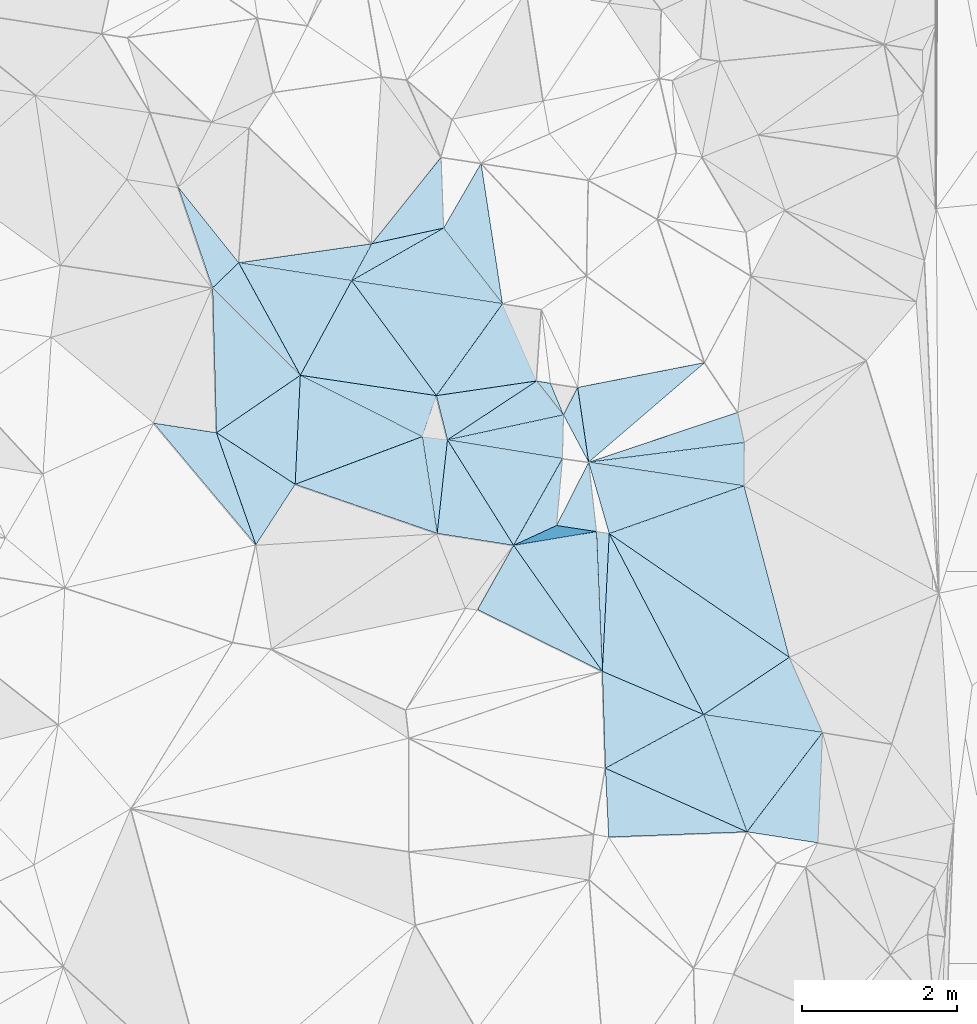
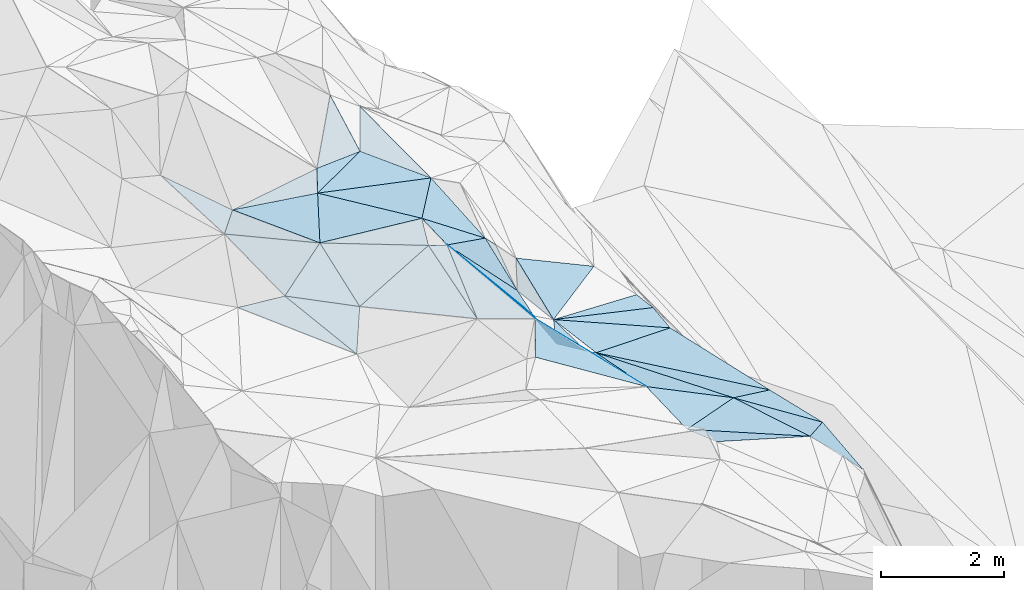
# One storey, part 136 of 275: 45 plates.
"""IFC2X3 building model written with IfcOpenShell, lengths in millimetres."""

from ifc_helpers import new_model, si_unit, frame, origin_with_axes, place, context, subcontext, project, spatial, polyline, outline, extrude, material, type_object, element, save


model = new_model("IFC2X3")

# Units and contexts
model_context = context("Model", 3, precision=1e-05, world=origin_with_axes())
body_context = subcontext(model_context, "Body", "Model", "MODEL_VIEW")
ifc_project = project(units=[si_unit("LENGTHUNIT", "METRE", prefix="MILLI"), si_unit("AREAUNIT", "SQUARE_METRE"), si_unit("VOLUMEUNIT", "CUBIC_METRE"), si_unit("MASSUNIT", "GRAM", prefix="KILO"), si_unit("TIMEUNIT", "SECOND"), si_unit("PLANEANGLEUNIT", "RADIAN"), si_unit("SOLIDANGLEUNIT", "STERADIAN"), si_unit("THERMODYNAMICTEMPERATUREUNIT", "DEGREE_CELSIUS"), si_unit("LUMINOUSINTENSITYUNIT", "LUMEN")], contexts=[model_context])

# Site, building, storey
site_placement = place(None, origin_with_axes())
site = spatial("IfcSite", under=ifc_project, at=site_placement, CompositionType="ELEMENT")
building_placement = place(site_placement, origin_with_axes())
building = spatial("IfcBuilding", under=site, at=building_placement, Name="Undefined", CompositionType="ELEMENT")
storey_placement = place(building_placement, origin_with_axes())
storey = spatial("IfcBuildingStorey", under=building, at=storey_placement, Name="Undefined", CompositionType="ELEMENT", Elevation=0.0)

# Plates
ifc_material = material()
plate_type_1 = type_object("IfcPlateType", PredefinedType="NOTDEFINED")
plate_1_placement = place(storey_placement, frame((-103066.712110477, 126934.664833472, 51469.7569913603), z_axis=(-0.382994864765174, -0.785585510736276, -0.485973598958555), x_axis=(0.529368234943565, 0.24448128612542, -0.812402715755675)))
element("IfcPlate", 1, at=plate_1_placement, inside=storey, type_object=plate_type_1, material=ifc_material, Name="00", context=body_context, shape_type="SweptSolid", body=[
    extrude(outline(polyline([(0.0, 0.0), (1046.27917480469, -4.88944351673126e-09), (1527.60388183594, 344.567138671875), (0.0, 0.0)])), frame((-8.85201319254618e-08, 2.18876761149539e-07, -0.5000001331573), z_axis=(0.0, 0.0, 1.0), x_axis=(1.0, 0.0, 0.0)), (0.0, 0.0, 1.0), 1.0),
])
plate_type_2 = type_object("IfcPlateType", PredefinedType="NOTDEFINED")
plate_2_placement = place(storey_placement, frame((-103066.905814277, 126935.033326246, 51469.6821244165), z_axis=(-0.770398967847582, -0.048593836914504, -0.63570753444749), x_axis=(-0.459656163311664, 0.733295490730213, 0.500992948856905)))
element("IfcPlate", 2, at=plate_2_placement, inside=storey, type_object=plate_type_2, material=ifc_material, Name="00", context=body_context, shape_type="SweptSolid", body=[
    extrude(outline(polyline([(0.0, 0.0), (1856.31359863281, -1.67819962371141e-08), (106.070442199707, 1537.87158203125), (0.0, 0.0)])), frame((-8.85201319254618e-08, 2.18876761149539e-07, -0.5000001331573), z_axis=(0.0, 0.0, 1.0), x_axis=(1.0, 0.0, 0.0)), (0.0, 0.0, 1.0), 1.0),
])
plate_type_3 = type_object("IfcPlateType", PredefinedType="NOTDEFINED")
plate_3_placement = place(storey_placement, frame((-101997.244580157, 127112.707123264, 50339.5594587975), z_axis=(-0.468511896336953, 0.0653125295690562, -0.881039656583087), x_axis=(-0.871098725838898, 0.132070881643551, 0.473016164696032)))
element("IfcPlate", 3, at=plate_3_placement, inside=storey, type_object=plate_type_3, material=ifc_material, Name="00", context=body_context, shape_type="SweptSolid", body=[
    extrude(outline(polyline([(0.0, 0.0), (591.945922851563, 2.6775524020195e-09), (262.861846923828, 870.519165039063), (0.0, 0.0)])), frame((-8.85201319254618e-08, 2.18876761149539e-07, -0.5000001331573), z_axis=(0.0, 0.0, 1.0), x_axis=(1.0, 0.0, 0.0)), (0.0, 0.0, 1.0), 1.0),
])
plate_type_4 = type_object("IfcPlateType", PredefinedType="NOTDEFINED")
plate_4_placement = place(storey_placement, frame((-100054.218506204, 123237.319774873, 50329.5073180374), z_axis=(-0.166949221869604, -0.0356923058343143, -0.985319246042298), x_axis=(-0.903457630635159, 0.405727496938867, 0.138381746899025)))
element("IfcPlate", 4, at=plate_4_placement, inside=storey, type_object=plate_type_4, material=ifc_material, Name="00", context=body_context, shape_type="SweptSolid", body=[
    extrude(outline(polyline([(0.0, 0.0), (2023.38830566406, -8.1636244431138e-09), (1124.89538574219, 1156.85375976563), (0.0, 0.0)])), frame((-8.85201319254618e-08, 2.18876761149539e-07, -0.5000001331573), z_axis=(0.0, 0.0, 1.0), x_axis=(1.0, 0.0, 0.0)), (0.0, 0.0, 1.0), 1.0),
])
plate_type_5 = type_object("IfcPlateType", PredefinedType="NOTDEFINED")
plate_5_placement = place(storey_placement, frame((-99138.9172299272, 123095.451423728, 49429.6417535888), z_axis=(-0.695161090337773, 0.0587561923549518, -0.7164487199656), x_axis=(-0.708825402116487, 0.109870213789418, 0.696774773823126)))
element("IfcPlate", 5, at=plate_5_placement, inside=storey, type_object=plate_type_5, material=ifc_material, Name="00", context=body_context, shape_type="SweptSolid", body=[
    extrude(outline(polyline([(0.0, 0.0), (1291.66564941406, 3.20142135024071e-09), (156.851745605469, 1419.25952148438), (0.0, 0.0)])), frame((-8.85201319254618e-08, 2.18876761149539e-07, -0.5000001331573), z_axis=(0.0, 0.0, 1.0), x_axis=(1.0, 0.0, 0.0)), (0.0, 0.0, 1.0), 1.0),
])
plate_type_6 = type_object("IfcPlateType", PredefinedType="NOTDEFINED")
plate_6_placement = place(storey_placement, frame((-105156.498019065, 130351.74544064, 52609.5000495979), z_axis=(0.0169326651673367, -0.000995935769564244, -0.999856136132731), x_axis=(0.593086249346957, -0.80506587780859, 0.0108458851110849)))
element("IfcPlate", 6, at=plate_6_placement, inside=storey, type_object=plate_type_6, material=ifc_material, Name="00", context=body_context, shape_type="SweptSolid", body=[
    extrude(outline(polyline([(0.0, 0.0), (1844.01733398438, 8.07540345704183e-09), (590.992248535156, 1258.3037109375), (0.0, 0.0)])), frame((-8.85201319254618e-08, 2.18876761149539e-07, -0.5000001331573), z_axis=(0.0, 0.0, 1.0), x_axis=(1.0, 0.0, 0.0)), (0.0, 0.0, 1.0), 1.0),
])
plate_type_7 = type_object("IfcPlateType", PredefinedType="NOTDEFINED")
plate_7_placement = place(storey_placement, frame((-105885.6027306, 127722.540343427, 52219.517241614), z_axis=(0.0183046440827062, 0.2598589496467, -0.965473079010243), x_axis=(-0.829176545301088, 0.543523481743129, 0.130569833868237)))
element("IfcPlate", 7, at=plate_7_placement, inside=storey, type_object=plate_type_7, material=ifc_material, Name="00", context=body_context, shape_type="SweptSolid", body=[
    extrude(outline(polyline([(0.0, 0.0), (1225.39794921875, 4.59112925454974e-09), (759.100402832031, 1246.06042480469), (0.0, 0.0)])), frame((-8.85201319254618e-08, 2.18876761149539e-07, -0.5000001331573), z_axis=(0.0, 0.0, 1.0), x_axis=(1.0, 0.0, 0.0)), (0.0, 0.0, 1.0), 1.0),
])
plate_type_8 = type_object("IfcPlateType", PredefinedType="NOTDEFINED")
plate_8_placement = place(storey_placement, frame((-103209.69435404, 130053.542712366, 52409.5065180733), z_axis=(-0.0799384784793379, 0.139991515799909, -0.986920571861005), x_axis=(-0.983409152696875, 0.150666100545945, 0.101025563786073)))
element("IfcPlate", 8, at=plate_8_placement, inside=storey, type_object=plate_type_8, material=ifc_material, Name="00", context=body_context, shape_type="SweptSolid", body=[
    extrude(outline(polyline([(0.0, 0.0), (1979.69689941406, 5.2241375669837e-09), (914.281372070313, 856.790283203125), (0.0, 0.0)])), frame((-8.85201319254618e-08, 2.18876761149539e-07, -0.5000001331573), z_axis=(0.0, 0.0, 1.0), x_axis=(1.0, 0.0, 0.0)), (0.0, 0.0, 1.0), 1.0),
])
plate_type_9 = type_object("IfcPlateType", PredefinedType="NOTDEFINED")
plate_9_placement = place(storey_placement, frame((-104002.079675067, 131944.846912686, 53179.5834194462), z_axis=(-0.210377469190595, 0.511525957004298, -0.833116147825618), x_axis=(0.030345762468046, -0.848360430690133, -0.528548686820321)))
element("IfcPlate", 9, at=plate_9_placement, inside=storey, type_object=plate_type_9, material=ifc_material, Name="00", context=body_context, shape_type="SweptSolid", body=[
    extrude(outline(polyline([(0.0, 0.0), (1078.4248046875, -5.28234522789717e-09), (1163.734375, 951.746948242188), (0.0, 0.0)])), frame((-8.85201319254618e-08, 2.18876761149539e-07, -0.5000001331573), z_axis=(0.0, 0.0, 1.0), x_axis=(1.0, 0.0, 0.0)), (0.0, 0.0, 1.0), 1.0),
])
plate_type_10 = type_object("IfcPlateType", PredefinedType="NOTDEFINED")
plate_10_placement = place(storey_placement, frame((-105156.595969258, 130351.902646769, 52609.5336799128), z_axis=(-0.178971071812995, 0.31342142105299, -0.93259657316507), x_axis=(0.469817430518854, 0.860067539019445, 0.198885420043041)))
element("IfcPlate", 10, at=plate_10_placement, inside=storey, type_object=plate_type_10, material=ifc_material, Name="00", context=body_context, shape_type="SweptSolid", body=[
    extrude(outline(polyline([(0.0, 0.0), (553.082275390625, 2.06637196242809e-09), (1140.87915039063, 753.388916015625), (0.0, 0.0)])), frame((-8.85201319254618e-08, 2.18876761149539e-07, -0.5000001331573), z_axis=(0.0, 0.0, 1.0), x_axis=(1.0, 0.0, 0.0)), (0.0, 0.0, 1.0), 1.0),
])
plate_type_11 = type_object("IfcPlateType", PredefinedType="NOTDEFINED")
plate_11_placement = place(storey_placement, frame((-104053.209064969, 127089.545762139, 51719.5724973247), z_axis=(-0.145791464487373, 0.497780816117161, -0.854961465791506), x_axis=(-0.129837787394665, 0.847093099972046, 0.515340109970306)))
element("IfcPlate", 11, at=plate_11_placement, inside=storey, type_object=plate_type_11, material=ifc_material, Name="00", context=body_context, shape_type="SweptSolid", body=[
    extrude(outline(polyline([(0.0, 0.0), (1474.75427246094, -9.41508915275335e-09), (1355.5478515625, 315.420135498047), (0.0, 0.0)])), frame((-8.85201319254618e-08, 2.18876761149539e-07, -0.5000001331573), z_axis=(0.0, 0.0, 1.0), x_axis=(1.0, 0.0, 0.0)), (0.0, 0.0, 1.0), 1.0),
])
plate_type_12 = type_object("IfcPlateType", PredefinedType="NOTDEFINED")
plate_12_placement = place(storey_placement, frame((-100173.620638357, 128651.436566187, 49889.5240167244), z_axis=(-0.300994349342359, 0.0569460371075263, -0.951924130654181), x_axis=(0.2106562983872, -0.96958546479659, -0.124611196948681)))
element("IfcPlate", 12, at=plate_12_placement, inside=storey, type_object=plate_type_12, material=ifc_material, Name="00", context=body_context, shape_type="SweptSolid", body=[
    extrude(outline(polyline([(0.0, 0.0), (401.248046875, -9.53150447458029e-10), (147.041213989258, 2102.32690429688), (0.0, 0.0)])), frame((-8.85201319254618e-08, 2.18876761149539e-07, -0.5000001331573), z_axis=(0.0, 0.0, 1.0), x_axis=(1.0, 0.0, 0.0)), (0.0, 0.0, 1.0), 1.0),
])
plate_type_13 = type_object("IfcPlateType", PredefinedType="NOTDEFINED")
plate_13_placement = place(storey_placement, frame((-99508.7822092477, 125490.317361758, 49689.5681303042), z_axis=(-0.502106992912468, -0.0438027793652822, -0.863695481166988), x_axis=(0.397332946452071, -0.898749384145857, -0.185407858951985)))
element("IfcPlate", 13, at=plate_13_placement, inside=storey, type_object=plate_type_13, material=ifc_material, Name="00", context=body_context, shape_type="SweptSolid", body=[
    extrude(outline(polyline([(0.0, 0.0), (1078.70288085938, -5.49334799870849e-09), (99.9348373413086, 1490.44055175781), (0.0, 0.0)])), frame((-8.85201319254618e-08, 2.18876761149539e-07, -0.5000001331573), z_axis=(0.0, 0.0, 1.0), x_axis=(1.0, 0.0, 0.0)), (0.0, 0.0, 1.0), 1.0),
])
plate_type_14 = type_object("IfcPlateType", PredefinedType="NOTDEFINED")
plate_14_placement = place(storey_placement, frame((-102422.71177586, 128619.656924779, 50779.7394256454), z_axis=(-0.364909545924037, 0.771550032679536, -0.521106102790708), x_axis=(-0.329776131223322, 0.416305903744311, 0.847311688685463)))
element("IfcPlate", 14, at=plate_14_placement, inside=storey, type_object=plate_type_14, material=ifc_material, Name="00", context=body_context, shape_type="SweptSolid", body=[
    extrude(outline(polyline([(0.0, 0.0), (1050.380859375, 2.39379005506635e-09), (834.935241699219, 122.405754089355), (0.0, 0.0)])), frame((-8.85201319254618e-08, 2.18876761149539e-07, -0.5000001331573), z_axis=(0.0, 0.0, 1.0), x_axis=(1.0, 0.0, 0.0)), (0.0, 0.0, 1.0), 1.0),
])
plate_type_15 = type_object("IfcPlateType", PredefinedType="NOTDEFINED")
plate_15_placement = place(storey_placement, frame((-105818.854998425, 129129.679469331, 52599.5172975869), z_axis=(0.0546115083904308, 0.255140506767915, -0.965360505178005), x_axis=(0.988881310890819, -0.147744193600586, 0.0168939701718752)))
element("IfcPlate", 15, at=plate_15_placement, inside=storey, type_object=plate_type_15, material=ifc_material, Name="00", context=body_context, shape_type="SweptSolid", body=[
    extrude(outline(polyline([(0.0, 0.0), (1775.78149414063, -5.47152012586594e-09), (1671.60205078125, 569.338745117188), (0.0, 0.0)])), frame((-8.85201319254618e-08, 2.18876761149539e-07, -0.5000001331573), z_axis=(0.0, 0.0, 1.0), x_axis=(1.0, 0.0, 0.0)), (0.0, 0.0, 1.0), 1.0),
])
plate_type_16 = type_object("IfcPlateType", PredefinedType="NOTDEFINED")
plate_16_placement = place(storey_placement, frame((-101839.387213726, 123169.617460363, 50889.543433549), z_axis=(-0.275045769895262, -0.301033493713015, -0.913087432903147), x_axis=(-0.0460346862578489, 0.952751163976744, -0.300243280028215)))
element("IfcPlate", 16, at=plate_16_placement, inside=storey, type_object=plate_type_16, material=ifc_material, Name="00", context=body_context, shape_type="SweptSolid", body=[
    extrude(outline(polyline([(0.0, 0.0), (932.577087402344, -4.13274392485619e-09), (150.33610534668, 1866.06518554688), (0.0, 0.0)])), frame((-8.85201319254618e-08, 2.18876761149539e-07, -0.5000001331573), z_axis=(0.0, 0.0, 1.0), x_axis=(1.0, 0.0, 0.0)), (0.0, 0.0, 1.0), 1.0),
])
plate_type_17 = type_object("IfcPlateType", PredefinedType="NOTDEFINED")
plate_17_placement = place(storey_placement, frame((-106614.10627522, 130582.056217532, 52649.5002354911), z_axis=(-0.0240748526667977, 0.0212253111247424, -0.999484811108568), x_axis=(0.98738418304366, -0.15600724560056, -0.0270963908174355)))
element("IfcPlate", 17, at=plate_17_placement, inside=storey, type_object=plate_type_17, material=ifc_material, Name="00", context=body_context, shape_type="SweptSolid", body=[
    extrude(outline(polyline([(0.0, 0.0), (1476.21142578125, -2.3283064365387e-10), (1013.13403320313, 1310.78576660156), (0.0, 0.0)])), frame((-8.85201319254618e-08, 2.18876761149539e-07, -0.5000001331573), z_axis=(0.0, 0.0, 1.0), x_axis=(1.0, 0.0, 0.0)), (0.0, 0.0, 1.0), 1.0),
])
plate_type_18 = type_object("IfcPlateType", PredefinedType="NOTDEFINED")
plate_18_placement = place(storey_placement, frame((-105818.854296588, 129129.680809976, 52599.5176946139), z_axis=(0.0560211159721772, 0.257825415463016, -0.964566062904224), x_axis=(0.891481974421891, -0.447930950772442, -0.0679540478628291)))
element("IfcPlate", 18, at=plate_18_placement, inside=storey, type_object=plate_type_18, material=ifc_material, Name="00", context=body_context, shape_type="SweptSolid", body=[
    extrude(outline(polyline([(0.0, 0.0), (1765.89916992188, -2.35741026699543e-09), (596.636535644531, 1331.51220703125), (0.0, 0.0)])), frame((-8.85201319254618e-08, 2.18876761149539e-07, -0.5000001331573), z_axis=(0.0, 0.0, 1.0), x_axis=(1.0, 0.0, 0.0)), (0.0, 0.0, 1.0), 1.0),
])
plate_type_19 = type_object("IfcPlateType", PredefinedType="NOTDEFINED")
plate_19_placement = place(storey_placement, frame((-102098.054796665, 128008.632321215, 50459.630739177), z_axis=(-0.505823591700289, 0.445861525208466, -0.738478161097672), x_axis=(-0.119673009436762, 0.811523430091826, 0.571933644074508)))
element("IfcPlate", 19, at=plate_19_placement, inside=storey, type_object=plate_type_19, material=ifc_material, Name="00", context=body_context, shape_type="SweptSolid", body=[
    extrude(outline(polyline([(0.0, 0.0), (1188.94909667969, 7.11588654667139e-09), (720.972839355469, 1854.64233398438), (0.0, 0.0)])), frame((-8.85201319254618e-08, 2.18876761149539e-07, -0.5000001331573), z_axis=(0.0, 0.0, 1.0), x_axis=(1.0, 0.0, 0.0)), (0.0, 0.0, 1.0), 1.0),
])
plate_type_20 = type_object("IfcPlateType", PredefinedType="NOTDEFINED")
plate_20_placement = place(storey_placement, frame((-106614.09015682, 130582.156129076, 52649.5123642163), z_axis=(0.00816414637942778, 0.221055638284513, -0.975227025618405), x_axis=(0.989141382463957, 0.141329248330167, 0.0403158661536777)))
element("IfcPlate", 20, at=plate_20_placement, inside=storey, type_object=plate_type_20, material=ifc_material, Name="00", context=body_context, shape_type="SweptSolid", body=[
    extrude(outline(polyline([(0.0, 0.0), (1736.28918457031, 1.80443748831749e-09), (1407.599609375, 444.818176269531), (0.0, 0.0)])), frame((-8.85201319254618e-08, 2.18876761149539e-07, -0.5000001331573), z_axis=(0.0, 0.0, 1.0), x_axis=(1.0, 0.0, 0.0)), (0.0, 0.0, 1.0), 1.0),
])
plate_type_21 = type_object("IfcPlateType", PredefinedType="NOTDEFINED")
plate_21_placement = place(storey_placement, frame((-102769.257546251, 129056.812479674, 51669.7400439502), z_axis=(-0.675333978190998, 0.523126903156167, -0.519867541874812), x_axis=(0.329776131234809, -0.416305903726012, -0.847311688689983)))
element("IfcPlate", 21, at=plate_21_placement, inside=storey, type_object=plate_type_21, material=ifc_material, Name="00", context=body_context, shape_type="SweptSolid", body=[
    extrude(outline(polyline([(0.0, 0.0), (1050.380859375, 2.39379005506635e-09), (-681.562316894531, 1403.87780761719), (0.0, 0.0)])), frame((-8.85201319254618e-08, 2.18876761149539e-07, -0.5000001331573), z_axis=(0.0, 0.0, 1.0), x_axis=(1.0, 0.0, 0.0)), (0.0, 0.0, 1.0), 1.0),
])
plate_type_22 = type_object("IfcPlateType", PredefinedType="NOTDEFINED")
plate_22_placement = place(storey_placement, frame((-102422.354827003, 128619.557998692, 50779.6294801499), z_axis=(0.348997443232228, 0.573694274328088, -0.740996399600252), x_axis=(0.339843211480445, 0.659407972874778, 0.67058759078873)))
element("IfcPlate", 22, at=plate_22_placement, inside=storey, type_object=plate_type_22, material=ifc_material, Name="00", context=body_context, shape_type="SweptSolid", body=[
    extrude(outline(polyline([(0.0, 0.0), (536.842651367188, 2.73576006293297e-09), (-507.038726806641, 569.132446289063), (0.0, 0.0)])), frame((-8.85201319254618e-08, 2.18876761149539e-07, -0.5000001331573), z_axis=(0.0, 0.0, 1.0), x_axis=(1.0, 0.0, 0.0)), (0.0, 0.0, 1.0), 1.0),
])
plate_type_23 = type_object("IfcPlateType", PredefinedType="NOTDEFINED")
plate_23_placement = place(storey_placement, frame((-102097.954518476, 128008.461281645, 50459.5266815143), z_axis=(-0.305270069071518, 0.103782140430351, -0.94659360459321), x_axis=(0.948630073739691, 0.119923310330751, -0.292778726747594)))
element("IfcPlate", 23, at=plate_23_placement, inside=storey, type_object=plate_type_23, material=ifc_material, Name="00", context=body_context, shape_type="SweptSolid", body=[
    extrude(outline(polyline([(0.0, 0.0), (2117.64013671875, -9.74978320300579e-09), (2064.1845703125, 560.127197265625), (0.0, 0.0)])), frame((-8.85201319254618e-08, 2.18876761149539e-07, -0.5000001331573), z_axis=(0.0, 0.0, 1.0), x_axis=(1.0, 0.0, 0.0)), (0.0, 0.0, 1.0), 1.0),
])
plate_type_24 = type_object("IfcPlateType", PredefinedType="NOTDEFINED")
plate_24_placement = place(storey_placement, frame((-107395.99566594, 131559.526923699, 53019.5411455461), z_axis=(0.0572261287580706, 0.393214546177214, -0.917664149273585), x_axis=(0.59911415129813, -0.748794737727581, -0.283493693873082)))
element("IfcPlate", 24, at=plate_24_placement, inside=storey, type_object=plate_type_24, material=ifc_material, Name="00", context=body_context, shape_type="SweptSolid", body=[
    extrude(outline(polyline([(0.0, 0.0), (1305.14367675781, -6.87577994540334e-09), (1390.9580078125, 487.273956298828), (0.0, 0.0)])), frame((-8.85201319254618e-08, 2.18876761149539e-07, -0.5000001331573), z_axis=(0.0, 0.0, 1.0), x_axis=(1.0, 0.0, 0.0)), (0.0, 0.0, 1.0), 1.0),
])
plate_type_25 = type_object("IfcPlateType", PredefinedType="NOTDEFINED")
plate_25_placement = place(storey_placement, frame((-104063.146722964, 128867.27218365, 52629.6096196503), z_axis=(-0.60314689515624, 0.16338829004905, -0.780716395074572), x_axis=(0.797610766574611, 0.116726921239208, -0.591770133499721)))
element("IfcPlate", 25, at=plate_25_placement, inside=storey, type_object=plate_type_25, material=ifc_material, Name="00", context=body_context, shape_type="SweptSolid", body=[
    extrude(outline(polyline([(0.0, 0.0), (1622.25146484375, 9.37143340706825e-09), (183.572021484375, 604.649719238281), (0.0, 0.0)])), frame((-8.85201319254618e-08, 2.18876761149539e-07, -0.5000001331573), z_axis=(0.0, 0.0, 1.0), x_axis=(1.0, 0.0, 0.0)), (0.0, 0.0, 1.0), 1.0),
])
plate_26_placement = place(storey_placement, frame((-103209.637819242, 130053.585348105, 52409.5131117536), z_axis=(0.0331302819806398, 0.225267890240316, -0.973733414258009), x_axis=(-0.606222378485492, 0.779112777976185, 0.15961737692878)))
element("IfcPlate", 26, at=plate_26_placement, inside=storey, type_object=plate_type_25, material=ifc_material, Name="00", context=body_context, shape_type="SweptSolid", body=[
    extrude(outline(polyline([(0.0, 0.0), (1252.99645996094, 1.09139364212751e-08), (1645.65515136719, 907.314208984375), (0.0, 0.0)])), frame((-8.85201319254618e-08, 2.18876761149539e-07, -0.5000001331573), z_axis=(0.0, 0.0, 1.0), x_axis=(1.0, 0.0, 0.0)), (0.0, 0.0, 1.0), 1.0),
])
plate_type_26 = type_object("IfcPlateType", PredefinedType="NOTDEFINED")
plate_27_placement = place(storey_placement, frame((-102436.242633563, 128055.816597882, 50619.7357655988), z_axis=(-0.845649645593804, 0.0751215211701313, -0.528425428952997), x_axis=(-0.0884844706384615, -0.996077556446199, -1.45631143495468e-11)))
element("IfcPlate", 27, at=plate_27_placement, inside=storey, type_object=plate_type_26, material=ifc_material, Name="00", context=body_context, shape_type="SweptSolid", body=[
    extrude(outline(polyline([(0.0, 0.0), (868.331726074219, -3.91446519643068e-09), (1172.13269042969, 1001.20178222656), (0.0, 0.0)])), frame((-8.85201319254618e-08, 2.18876761149539e-07, -0.5000001331573), z_axis=(0.0, 0.0, 1.0), x_axis=(1.0, 0.0, 0.0)), (0.0, 0.0, 1.0), 1.0),
])
plate_type_27 = type_object("IfcPlateType", PredefinedType="NOTDEFINED")
plate_28_placement = place(storey_placement, frame((-101921.481577274, 125309.395571691, 50709.5338117634), z_axis=(-0.255568071387647, 0.255816673667284, -0.932331909976809), x_axis=(-0.841164731122259, 0.416541404691041, 0.344869762800441)))
element("IfcPlate", 28, at=plate_28_placement, inside=storey, type_object=plate_type_27, material=ifc_material, Name="00", context=body_context, shape_type="SweptSolid", body=[
    extrude(outline(polyline([(0.0, 0.0), (1913.76586914063, 1.4202669262886e-08), (1902.58374023438, 955.183227539063), (0.0, 0.0)])), frame((-8.85201319254618e-08, 2.18876761149539e-07, -0.5000001331573), z_axis=(0.0, 0.0, 1.0), x_axis=(1.0, 0.0, 0.0)), (0.0, 0.0, 1.0), 1.0),
])
plate_type_28 = type_object("IfcPlateType", PredefinedType="NOTDEFINED")
plate_29_placement = place(storey_placement, frame((-105818.745859865, 129129.64285734, 52599.5276334876), z_axis=(0.272887615497557, 0.181920195959619, -0.944689044929638), x_axis=(-0.706903687159132, 0.703971902597636, -0.068634812113745)))
element("IfcPlate", 29, at=plate_29_placement, inside=storey, type_object=plate_type_28, material=ifc_material, Name="00", context=body_context, shape_type="SweptSolid", body=[
    extrude(outline(polyline([(0.0, 0.0), (1602.68530273438, -4.03451849706471e-09), (1581.22131347656, 494.306884765625), (0.0, 0.0)])), frame((-8.85201319254618e-08, 2.18876761149539e-07, -0.5000001331573), z_axis=(0.0, 0.0, 1.0), x_axis=(1.0, 0.0, 0.0)), (0.0, 0.0, 1.0), 1.0),
])
plate_type_29 = type_object("IfcPlateType", PredefinedType="NOTDEFINED")
plate_30_placement = place(storey_placement, frame((-106951.747592406, 130257.828390746, 52489.5072110301), z_axis=(0.157650796338477, 0.0622213420355203, -0.985532714327202), x_axis=(0.706903687151833, -0.703971902605073, 0.0686348121126382)))
element("IfcPlate", 30, at=plate_30_placement, inside=storey, type_object=plate_type_29, material=ifc_material, Name="00", context=body_context, shape_type="SweptSolid", body=[
    extrude(outline(polyline([(0.0, 0.0), (1602.68530273438, -4.03451849706471e-09), (1343.86962890625, 1305.03430175781), (0.0, 0.0)])), frame((-8.85201319254618e-08, 2.18876761149539e-07, -0.5000001331573), z_axis=(0.0, 0.0, 1.0), x_axis=(1.0, 0.0, 0.0)), (0.0, 0.0, 1.0), 1.0),
])
plate_type_30 = type_object("IfcPlateType", PredefinedType="NOTDEFINED")
plate_31_placement = place(storey_placement, frame((-102097.95420338, 128008.463122395, 50459.5267854741), z_axis=(-0.304639986242196, 0.107456160288257, -0.946386629448271), x_axis=(0.937293472129498, -0.142832318640888, -0.317930614844021)))
element("IfcPlate", 31, at=plate_31_placement, inside=storey, type_object=plate_type_30, material=ifc_material, Name="00", context=body_context, shape_type="SweptSolid", body=[
    extrude(outline(polyline([(0.0, 0.0), (2138.83154296875, 1.73895386978984e-08), (440.614440917969, 872.558837890625), (0.0, 0.0)])), frame((-8.85201319254618e-08, 2.18876761149539e-07, -0.5000001331573), z_axis=(0.0, 0.0, 1.0), x_axis=(1.0, 0.0, 0.0)), (0.0, 0.0, 1.0), 1.0),
])
plate_type_31 = type_object("IfcPlateType", PredefinedType="NOTDEFINED")
plate_32_placement = place(storey_placement, frame((-107710.637179416, 128512.032526611, 52359.5274765228), z_axis=(0.0720376060008373, 0.319027932322037, -0.945003577622854), x_axis=(0.988264988974802, -0.150782577605809, 0.0244320661668805)))
element("IfcPlate", 32, at=plate_32_placement, inside=storey, type_object=plate_type_31, material=ifc_material, Name="00", context=body_context, shape_type="SweptSolid", body=[
    extrude(outline(polyline([(0.0, 0.0), (818.596374511719, 2.57568899542093e-09), (1528.83654785156, 1432.95458984375), (0.0, 0.0)])), frame((-8.85201319254618e-08, 2.18876761149539e-07, -0.5000001331573), z_axis=(0.0, 0.0, 1.0), x_axis=(1.0, 0.0, 0.0)), (0.0, 0.0, 1.0), 1.0),
])
plate_33_placement = place(storey_placement, frame((-103920.156123835, 128296.384013575, 52399.6783753221), z_axis=(-0.739093446408522, 0.200066522969889, -0.643206237425224), x_axis=(0.671577886142036, 0.144872261278284, -0.726632761962404)))
element("IfcPlate", 33, at=plate_33_placement, inside=storey, type_object=plate_type_31, material=ifc_material, Name="00", context=body_context, shape_type="SweptSolid", body=[
    extrude(outline(polyline([(0.0, 0.0), (2229.4619140625, -7.6834112405777e-09), (2255.1630859375, 585.354125976563), (0.0, 0.0)])), frame((-8.85201319254618e-08, 2.18876761149539e-07, -0.5000001331573), z_axis=(0.0, 0.0, 1.0), x_axis=(1.0, 0.0, 0.0)), (0.0, 0.0, 1.0), 1.0),
])
plate_type_32 = type_object("IfcPlateType", PredefinedType="NOTDEFINED")
plate_34_placement = place(storey_placement, frame((-106901.654600935, 128388.600199116, 52379.5262063235), z_axis=(0.0569557986481917, 0.314515956208268, -0.947541951731292), x_axis=(0.82917654531454, -0.543523481723511, -0.130569833864479)))
element("IfcPlate", 34, at=plate_34_placement, inside=storey, type_object=plate_type_32, material=ifc_material, Name="00", context=body_context, shape_type="SweptSolid", body=[
    extrude(outline(polyline([(0.0, 0.0), (1225.39794921875, 4.59112925454974e-09), (1267.669921875, 975.096435546875), (0.0, 0.0)])), frame((-8.85201319254618e-08, 2.18876761149539e-07, -0.5000001331573), z_axis=(0.0, 0.0, 1.0), x_axis=(1.0, 0.0, 0.0)), (0.0, 0.0, 1.0), 1.0),
])
plate_type_33 = type_object("IfcPlateType", PredefinedType="NOTDEFINED")
plate_35_placement = place(storey_placement, frame((-103919.856140571, 128296.532828642, 52399.5719183398), z_axis=(-0.139127652211571, 0.497697154299075, -0.856119757389525), x_axis=(0.459656163299547, -0.73329549074023, -0.500992948853359)))
element("IfcPlate", 35, at=plate_35_placement, inside=storey, type_object=plate_type_33, material=ifc_material, Name="00", context=body_context, shape_type="SweptSolid", body=[
    extrude(outline(polyline([(0.0, 0.0), (1856.31359863281, -1.67819962371141e-08), (1164.45849609375, 762.257507324219), (0.0, 0.0)])), frame((-8.85201319254618e-08, 2.18876761149539e-07, -0.5000001331573), z_axis=(0.0, 0.0, 1.0), x_axis=(1.0, 0.0, 0.0)), (0.0, 0.0, 1.0), 1.0),
])
plate_type_34 = type_object("IfcPlateType", PredefinedType="NOTDEFINED")
plate_36_placement = place(storey_placement, frame((-99508.6617919409, 125490.324375555, 49689.5175711475), z_axis=(-0.261238522487064, -0.0297733086965178, -0.964815000120768), x_axis=(-0.807329408452942, 0.554639112834167, 0.201481216895151)))
element("IfcPlate", 36, at=plate_36_placement, inside=storey, type_object=plate_type_34, material=ifc_material, Name="00", context=body_context, shape_type="SweptSolid", body=[
    extrude(outline(polyline([(0.0, 0.0), (2878.68017578125, -5.67524693906307e-09), (1717.24523925781, 1515.37744140625), (0.0, 0.0)])), frame((-8.85201319254618e-08, 2.18876761149539e-07, -0.5000001331573), z_axis=(0.0, 0.0, 1.0), x_axis=(1.0, 0.0, 0.0)), (0.0, 0.0, 1.0), 1.0),
])
plate_type_35 = type_object("IfcPlateType", PredefinedType="NOTDEFINED")
plate_37_placement = place(storey_placement, frame((-101921.465077865, 125309.303041372, 50709.5138043048), z_axis=(-0.222565772944961, 0.0707570347778028, -0.972346604222416), x_axis=(0.894313037231591, -0.382279343728571, -0.232522460842087)))
element("IfcPlate", 37, at=plate_37_placement, inside=storey, type_object=plate_type_35, material=ifc_material, Name="00", context=body_context, shape_type="SweptSolid", body=[
    extrude(outline(polyline([(0.0, 0.0), (1462.22436523438, -1.28202373161912e-08), (536.511413574219, 1135.18969726563), (0.0, 0.0)])), frame((-8.85201319254618e-08, 2.18876761149539e-07, -0.5000001331573), z_axis=(0.0, 0.0, 1.0), x_axis=(1.0, 0.0, 0.0)), (0.0, 0.0, 1.0), 1.0),
])
plate_38_placement = place(storey_placement, frame((-103209.952972902, 130053.618150659, 52409.6262191396), z_axis=(-0.597171865547441, 0.290864595433385, -0.747518260728099), x_axis=(0.334533593320542, -0.756700050692982, -0.561687019808438)))
element("IfcPlate", 38, at=plate_38_placement, inside=storey, type_object=plate_type_35, material=ifc_material, Name="00", context=body_context, shape_type="SweptSolid", body=[
    extrude(outline(polyline([(0.0, 0.0), (1317.45971679688, 4.07453626394272e-09), (488.667694091797, 1394.56225585938), (0.0, 0.0)])), frame((-8.85201319254618e-08, 2.18876761149539e-07, -0.5000001331573), z_axis=(0.0, 0.0, 1.0), x_axis=(1.0, 0.0, 0.0)), (0.0, 0.0, 1.0), 1.0),
])
plate_type_36 = type_object("IfcPlateType", PredefinedType="NOTDEFINED")
plate_39_placement = place(storey_placement, frame((-100613.832292107, 124750.183858082, 50369.5398859659), z_axis=(-0.329568827107815, -0.211296548394677, -0.920183762536199), x_axis=(-0.894313037229709, 0.382279343731579, 0.23252246084438)))
element("IfcPlate", 39, at=plate_39_placement, inside=storey, type_object=plate_type_36, material=ifc_material, Name="00", context=body_context, shape_type="SweptSolid", body=[
    extrude(outline(polyline([(0.0, 0.0), (1462.22436523438, -1.28202373161912e-08), (1960.09594726563, 1764.60302734375), (0.0, 0.0)])), frame((-8.85201319254618e-08, 2.18876761149539e-07, -0.5000001331573), z_axis=(0.0, 0.0, 1.0), x_axis=(1.0, 0.0, 0.0)), (0.0, 0.0, 1.0), 1.0),
])
plate_type_37 = type_object("IfcPlateType", PredefinedType="NOTDEFINED")
plate_40_placement = place(storey_placement, frame((-100613.922186101, 124750.20648568, 50369.5777757866), z_axis=(-0.509324281281545, -0.166037841711846, -0.844405241348435), x_axis=(0.860160150846338, -0.128672243638102, -0.493526056670914)))
element("IfcPlate", 40, at=plate_40_placement, inside=storey, type_object=plate_type_37, material=ifc_material, Name="00", context=body_context, shape_type="SweptSolid", body=[
    extrude(outline(polyline([(0.0, 0.0), (1783.08715820313, -9.47329681366682e-09), (695.703491210938, 1455.91784667969), (0.0, 0.0)])), frame((-8.85201319254618e-08, 2.18876761149539e-07, -0.5000001331573), z_axis=(0.0, 0.0, 1.0), x_axis=(1.0, 0.0, 0.0)), (0.0, 0.0, 1.0), 1.0),
])
plate_type_38 = type_object("IfcPlateType", PredefinedType="NOTDEFINED")
plate_41_placement = place(storey_placement, frame((-103066.871594795, 126934.971984123, 51469.6543230597), z_axis=(-0.701963637004841, -0.171282898247653, -0.691309786630292), x_axis=(0.682964558991132, 0.113422012215832, -0.721591891796852)))
element("IfcPlate", 41, at=plate_41_placement, inside=storey, type_object=plate_type_38, material=ifc_material, Name="00", context=body_context, shape_type="SweptSolid", body=[
    extrude(outline(polyline([(0.0, 0.0), (1565.98217773438, 7.10133463144302e-09), (1146.11779785156, 1794.04956054688), (0.0, 0.0)])), frame((-8.85201319254618e-08, 2.18876761149539e-07, -0.5000001331573), z_axis=(0.0, 0.0, 1.0), x_axis=(1.0, 0.0, 0.0)), (0.0, 0.0, 1.0), 1.0),
])
plate_type_39 = type_object("IfcPlateType", PredefinedType="NOTDEFINED")
plate_42_placement = place(storey_placement, frame((-104053.164517541, 127089.553144413, 51719.5715851054), z_axis=(-0.0566951632349465, 0.512546726107982, -0.856785569452329), x_axis=(-0.915231654874014, 0.316209133579151, 0.249725452763023)))
element("IfcPlate", 42, at=plate_42_placement, inside=storey, type_object=plate_type_39, material=ifc_material, Name="00", context=body_context, shape_type="SweptSolid", body=[
    extrude(outline(polyline([(0.0, 0.0), (2002.19873046875, -3.92901711165905e-10), (760.064392089844, 1263.80456542969), (0.0, 0.0)])), frame((-8.85201319254618e-08, 2.18876761149539e-07, -0.5000001331573), z_axis=(0.0, 0.0, 1.0), x_axis=(1.0, 0.0, 0.0)), (0.0, 0.0, 1.0), 1.0),
])
plate_type_40 = type_object("IfcPlateType", PredefinedType="NOTDEFINED")
plate_43_placement = place(storey_placement, frame((-101832.767932327, 127086.847922272, 50269.5548452162), z_axis=(-0.387067206397094, -0.240009714787696, -0.890266428963531), x_axis=(0.807329408439665, -0.554639112847876, -0.201481216910615)))
element("IfcPlate", 43, at=plate_43_placement, inside=storey, type_object=plate_type_40, material=ifc_material, Name="00", context=body_context, shape_type="SweptSolid", body=[
    extrude(outline(polyline([(0.0, 0.0), (2878.68017578125, -5.67524693906307e-09), (2259.92456054688, 1359.61071777344), (0.0, 0.0)])), frame((-8.85201319254618e-08, 2.18876761149539e-07, -0.5000001331573), z_axis=(0.0, 0.0, 1.0), x_axis=(1.0, 0.0, 0.0)), (0.0, 0.0, 1.0), 1.0),
])
plate_type_41 = type_object("IfcPlateType", PredefinedType="NOTDEFINED")
plate_44_placement = place(storey_placement, frame((-101997.215355151, 127112.574575392, 50339.5550249604), z_axis=(-0.410063776843902, -0.199782767513416, -0.889907042743901), x_axis=(0.910726362763019, -0.142375362781577, -0.387694142645018)))
element("IfcPlate", 44, at=plate_44_placement, inside=storey, type_object=plate_type_41, material=ifc_material, Name="00", context=body_context, shape_type="SweptSolid", body=[
    extrude(outline(polyline([(0.0, 0.0), (180.554702758789, -2.69210431724787e-10), (182.216247558594, 1833.4931640625), (0.0, 0.0)])), frame((-8.85201319254618e-08, 2.18876761149539e-07, -0.5000001331573), z_axis=(0.0, 0.0, 1.0), x_axis=(1.0, 0.0, 0.0)), (0.0, 0.0, 1.0), 1.0),
])
plate_type_42 = type_object("IfcPlateType", PredefinedType="NOTDEFINED")
plate_45_placement = place(storey_placement, frame((-104062.903512345, 128867.140833225, 52629.50588536), z_axis=(-0.116731048148447, -0.0993078143413264, -0.988186126399735), x_axis=(-0.593086249358079, 0.8050658778004, -0.010845885110923)))
element("IfcPlate", 45, at=plate_45_placement, inside=storey, type_object=plate_type_42, material=ifc_material, Name="00", context=body_context, shape_type="SweptSolid", body=[
    extrude(outline(polyline([(0.0, 0.0), (1844.01733398438, 8.07540345704183e-09), (451.405731201172, 1407.06530761719), (0.0, 0.0)])), frame((-8.85201319254618e-08, 2.18876761149539e-07, -0.5000001331573), z_axis=(0.0, 0.0, 1.0), x_axis=(1.0, 0.0, 0.0)), (0.0, 0.0, 1.0), 1.0),
])

save(model, "model.ifc")
